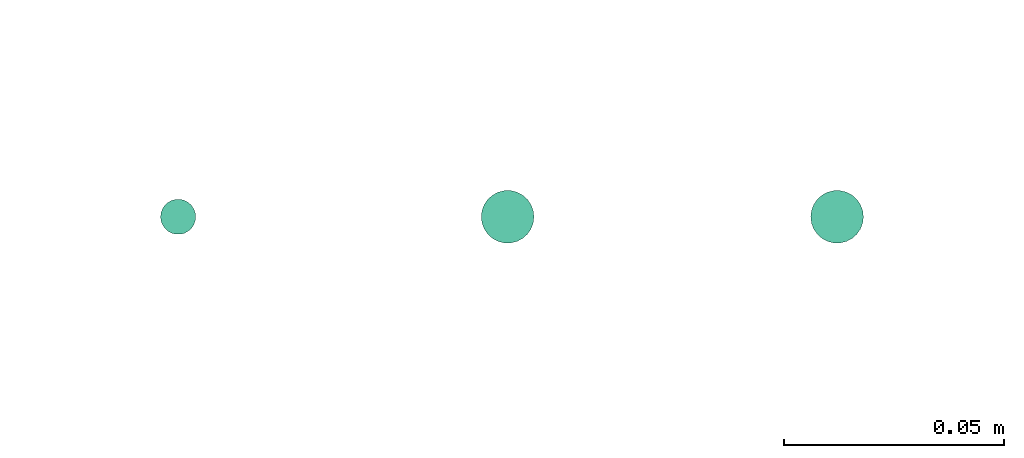
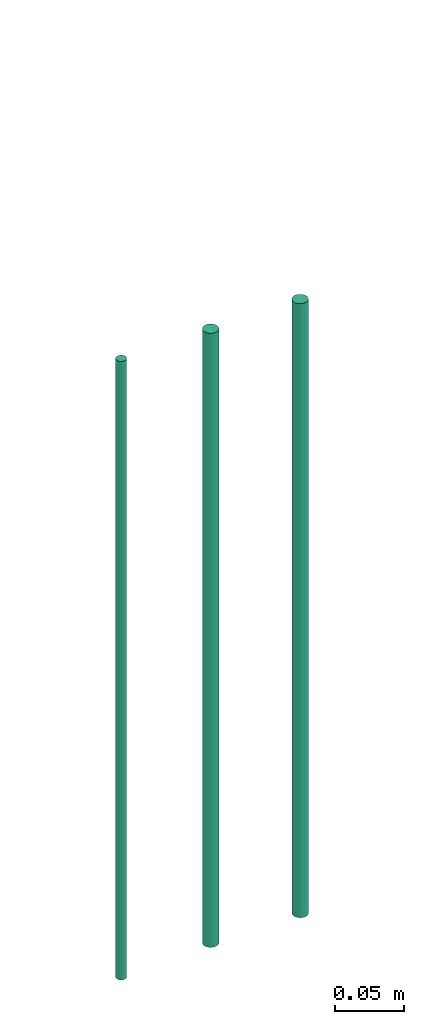
# One storey, part 29 of 65: 3 flow segments.
"""IFC2X3 building model written with IfcOpenShell, lengths in millimetres."""

from ifc_helpers import new_model, entity, si_unit, converted_unit, derived_unit, direction, frame, origin, origin_2d_with_axis, place, context, subcontext, project, spatial, circle, extrude, type_object, element, save


model = new_model("IFC2X3")

# Units and contexts
model_context = context("Model", 3, precision=0.01, world=origin(), true_north=direction((6.12303176911189e-17, 1.0)))
body_context = subcontext(model_context, "Body", "Model", "MODEL_VIEW")
ifc_project = project(units=[si_unit("LENGTHUNIT", "METRE", prefix="MILLI"), si_unit("AREAUNIT", "SQUARE_METRE"), si_unit("VOLUMEUNIT", "CUBIC_METRE"), converted_unit("PLANEANGLEUNIT", "DEGREE", entity("IfcRatioMeasure", 0.0174532925199433), si_unit("PLANEANGLEUNIT", "RADIAN"), dimensions=[0, 0, 0, 0, 0, 0, 0]), si_unit("MASSUNIT", "GRAM", prefix="KILO"), derived_unit("MASSDENSITYUNIT", [(si_unit("MASSUNIT", "GRAM", prefix="KILO"), 1), (si_unit("LENGTHUNIT", "METRE"), -3)]), derived_unit("MOMENTOFINERTIAUNIT", [(si_unit("LENGTHUNIT", "METRE"), 4)]), si_unit("TIMEUNIT", "SECOND"), si_unit("FREQUENCYUNIT", "HERTZ"), si_unit("THERMODYNAMICTEMPERATUREUNIT", "DEGREE_CELSIUS"), derived_unit("THERMALTRANSMITTANCEUNIT", [(si_unit("MASSUNIT", "GRAM", prefix="KILO"), 1), (si_unit("THERMODYNAMICTEMPERATUREUNIT", "KELVIN"), -1), (si_unit("TIMEUNIT", "SECOND"), -3)]), derived_unit("VOLUMETRICFLOWRATEUNIT", [(si_unit("LENGTHUNIT", "METRE"), 3), (si_unit("TIMEUNIT", "SECOND"), -1)]), derived_unit("MASSFLOWRATEUNIT", [(si_unit("MASSUNIT", "GRAM", prefix="KILO"), 1), (si_unit("TIMEUNIT", "SECOND"), -1)]), derived_unit("ROTATIONALFREQUENCYUNIT", [(si_unit("TIMEUNIT", "SECOND"), -1)]), si_unit("ELECTRICCURRENTUNIT", "AMPERE"), si_unit("ELECTRICVOLTAGEUNIT", "VOLT"), si_unit("POWERUNIT", "WATT"), si_unit("FORCEUNIT", "NEWTON", prefix="KILO"), si_unit("ILLUMINANCEUNIT", "LUX"), si_unit("LUMINOUSFLUXUNIT", "LUMEN"), si_unit("LUMINOUSINTENSITYUNIT", "CANDELA"), derived_unit("USERDEFINED", [(si_unit("MASSUNIT", "GRAM", prefix="KILO"), -1), (si_unit("LENGTHUNIT", "METRE"), -2), (si_unit("TIMEUNIT", "SECOND"), 3), (si_unit("LUMINOUSFLUXUNIT", "LUMEN"), 1)]), derived_unit("LINEARVELOCITYUNIT", [(si_unit("LENGTHUNIT", "METRE"), 1), (si_unit("TIMEUNIT", "SECOND"), -1)]), si_unit("PRESSUREUNIT", "PASCAL"), derived_unit("USERDEFINED", [(si_unit("LENGTHUNIT", "METRE"), -2), (si_unit("MASSUNIT", "GRAM", prefix="KILO"), 1), (si_unit("TIMEUNIT", "SECOND"), -2)]), derived_unit("LINEARFORCEUNIT", [(si_unit("MASSUNIT", "GRAM", prefix="KILO"), 1), (si_unit("LENGTHUNIT", "METRE"), 1), (si_unit("TIMEUNIT", "SECOND"), -2), (si_unit("LENGTHUNIT", "METRE"), -1)]), derived_unit("PLANARFORCEUNIT", [(si_unit("MASSUNIT", "GRAM", prefix="KILO"), 1), (si_unit("LENGTHUNIT", "METRE"), 1), (si_unit("TIMEUNIT", "SECOND"), -2), (si_unit("LENGTHUNIT", "METRE"), -2)])], contexts=[model_context])

# Site, building, storey
site_placement = place(None, frame((0.0, -0.00077364408347762, 0.0)))
site = spatial("IfcSite", under=ifc_project, at=site_placement, CompositionType="ELEMENT")
building_placement = place(site_placement, origin())
building = spatial("IfcBuilding", under=site, at=building_placement, CompositionType="ELEMENT")
storey_placement = place(building_placement, frame((0.0, 0.0, 19800.0)))
storey = spatial("IfcBuildingStorey", under=building, at=storey_placement, CompositionType="ELEMENT", Elevation=19800.0)

# Flow segments
pipe_segment_type = type_object("IfcPipeSegmentType", PredefinedType="NOTDEFINED")
flow_segment_placement = place(storey_placement, frame((21665.8822000101, 16317.65509256, -13115.0)))
element("IfcFlowSegment", 1, at=flow_segment_placement, inside=storey, type_object=pipe_segment_type, context=body_context, shape_type="SweptSolid", body=[
    extrude(circle(Radius=4.0, at=origin_2d_with_axis()), frame((5.59527223591499, 5.59527223591499, 0.0), z_axis=(0.0, 0.0, 1.0), x_axis=(-1.0, 0.0, 0.0)), (0.0, 0.0, 1.0), 548.000000000034),
])
for number, where in (
    (2, (21738.8822000101, 16315.65509256, -13111.0)),
    (3, (21813.8822000101, 16315.65509256, -13111.0)),
):
    element("IfcFlowSegment", number, at=place(storey_placement, frame(where)), inside=storey, type_object=pipe_segment_type, context=body_context, shape_type="SweptSolid", body=[
        extrude(circle(Radius=6.0, at=origin_2d_with_axis()), frame((7.59527223591454, 7.5952722359167, 0.0), z_axis=(0.0, 0.0, 1.0), x_axis=(-1.0, 0.0, 0.0)), (0.0, 0.0, 1.0), 544.000000000033),
    ])

save(model, "model.ifc")
